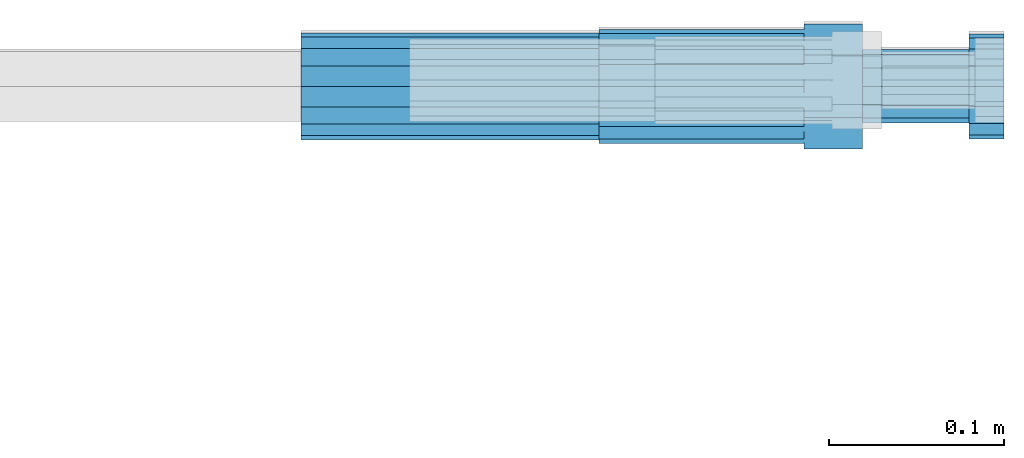
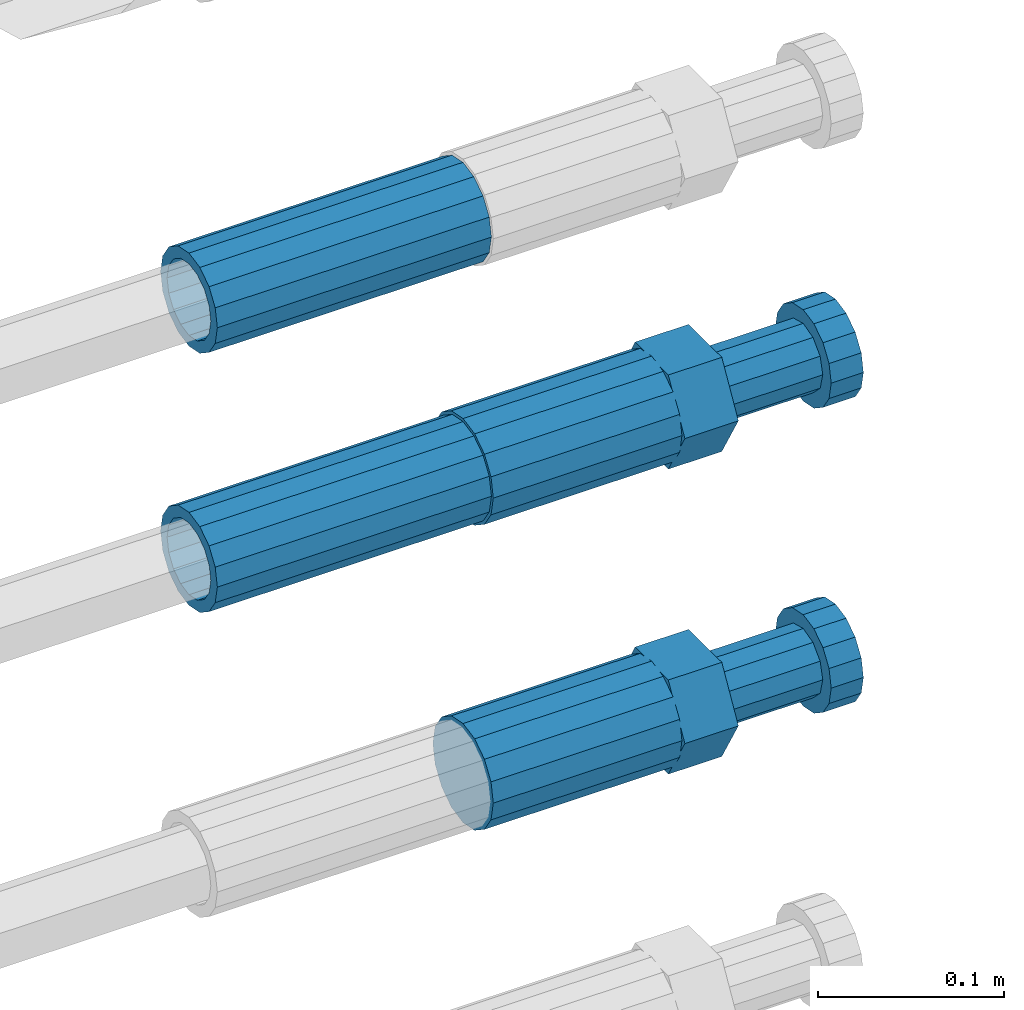
# One storey, part 116 of 119: 4 beams.
"""IFC2X3 building model written with IfcOpenShell, lengths in millimetres."""

from ifc_helpers import new_model, si_unit, frame, origin_with_axes, place, context, subcontext, project, spatial, faceted_brep, material, type_object, element, save


model = new_model("IFC2X3")

# Units and contexts
model_context = context("Model", 3, precision=1e-05, world=origin_with_axes())
body_context = subcontext(model_context, "Body", "Model", "MODEL_VIEW")
ifc_project = project(units=[si_unit("LENGTHUNIT", "METRE", prefix="MILLI"), si_unit("AREAUNIT", "SQUARE_METRE"), si_unit("VOLUMEUNIT", "CUBIC_METRE"), si_unit("MASSUNIT", "GRAM", prefix="KILO"), si_unit("TIMEUNIT", "SECOND"), si_unit("PLANEANGLEUNIT", "RADIAN"), si_unit("SOLIDANGLEUNIT", "STERADIAN"), si_unit("THERMODYNAMICTEMPERATUREUNIT", "DEGREE_CELSIUS"), si_unit("LUMINOUSINTENSITYUNIT", "LUMEN")], contexts=[model_context])

# Site, building, storey
site_placement = place(None, origin_with_axes())
site = spatial("IfcSite", under=ifc_project, at=site_placement, CompositionType="ELEMENT")
building_placement = place(site_placement, origin_with_axes())
building = spatial("IfcBuilding", under=site, at=building_placement, Name="Undefined", CompositionType="ELEMENT")
storey_placement = place(building_placement, origin_with_axes())
storey = spatial("IfcBuildingStorey", under=building, at=storey_placement, Name="Undefined", CompositionType="ELEMENT", Elevation=0.0)

# Beams
ifc_material = material(Name="STEEL/S275")
beam_type_1 = type_object("IfcBeamType", PredefinedType="NOTDEFINED")
beam_1_placement = place(storey_placement, frame((2039349.03023304, 6206399.98994599, 21634.9894122711), z_axis=(0.0, 0.0, 1.0), x_axis=(1.0, 0.0, 0.0)))
element("IfcBeam", 1, at=beam_1_placement, inside=storey, type_object=beam_type_1, material=ifc_material, Name="AG40N", context=body_context, shape_type="Brep", body=[
    faceted_brep([(1.62981450557709e-09, -23.4999999990687, 0.0), (7.45058059692383e-09, -21.7111690142192, 8.99306066057534), (170.000002125278, -21.711168999318, 8.99306066022245), (170.000002127141, -23.4999999844003, -3.66071617463604e-10), (4.65661287307739e-09, -16.6170093587134, 16.6170093578889), (170.000002122484, -16.6170093440451, 16.6170093575288), (1.86264514923096e-09, -8.99306066217832, 21.7111690140277), (170.000002118759, -8.99306064750999, 21.7111690136603), (2.3283064365387e-10, 9.31322574615479e-10, 23.5), (170.000002114102, 1.28056854009628e-08, 23.4999999996485), (-6.51925802230835e-09, 8.99306065868586, 21.7111690140241), (170.00000211224, 8.99306067335419, 21.7111690136639), (-7.45058059692383e-09, 16.6170093561523, 16.6170093578853), (170.000002109446, 16.6170093708206, 16.6170093575324), (-9.31322574615479e-09, 21.711169013055, 8.99306066057534), (170.000002108514, 21.7111690277234, 8.99306066022245), (-1.16415321826935e-09, 23.5000000009313, 0.0), (170.000002108514, 23.5000000144355, -3.66071617463604e-10), (-8.38190317153931e-09, 21.7111690151505, -8.99306066059444), (170.000002110377, 21.7111690300517, -8.9930606609546), (-5.58793544769287e-09, 16.6170093598776, -16.6170093579008), (170.000002113171, 16.6170093745459, -16.6170093582609), (-9.31322574615479e-10, 8.99306066334248, -21.7111690140396), (170.000002115965, 8.99306067801081, -21.7111690143961), (2.3283064365387e-10, 9.31322574615479e-10, -23.5), (170.00000211969, 1.7927959561348e-08, -23.5000000003843), (5.58793544769287e-09, -8.99306065752171, -21.7111690140396), (170.000002123415, -8.99306064285338, -21.7111690143961), (8.38190317153931e-09, -16.6170093549881, -16.6170093579008), (170.000002125278, -16.6170093403198, -16.6170093582646), (9.31322574615479e-09, -21.7111690121237, -8.99306066059444), (170.000002127141, -21.7111689972226, -8.9930606609546), (1.11758708953857e-08, -30.4999999990687, -9.54969436861575e-12), (1.30385160446167e-08, -28.1783257392235, -11.6718446871514), (170.000002129003, -28.1783257243223, -11.6718446875116), (170.000002129935, -30.4999999841675, -3.66071617463604e-10), (1.02445483207703e-08, -21.5667568228673, -21.5667568262129), (170.000002128072, -21.566756808199, -21.5667568265694), (7.45058059692383e-09, -11.6718446831219, -28.1783257416196), (170.000002125278, -11.6718446684536, -28.1783257419834), (3.72529029846191e-09, 3.95812094211578e-09, -30.5000000000277), (170.00000211969, 1.83936208486557e-08, -30.5000000003879), (-9.31322574615479e-10, 11.6718446905725, -28.1783257416232), (170.000002115965, 11.6718447052408, -28.1783257419797), (-6.51925802230835e-09, 21.5667568286881, -21.5667568262093), (170.000002110377, 21.5667568433564, -21.5667568265694), (-9.31322574615479e-09, 28.178325742716, -11.6718446871478), (170.000002108514, 28.1783257573843, -11.6718446875079), (-1.21071934700012e-08, 30.5, -5.91171556152403e-12), (170.000002106652, 30.5000000144355, -3.62433638656512e-10), (-1.21071934700012e-08, 28.1783257401548, 11.6718446871359), (170.00000210572, 28.1783257548232, 11.6718446867794), (-1.02445483207703e-08, 21.5667568240315, 21.5667568261974), (170.000002107583, 21.566756838467, 21.5667568258409), (-7.45058059692383e-09, 11.671844684286, 28.1783257416041), (170.000002110377, 11.6718446989544, 28.178325741244), (-2.79396772384644e-09, -2.56113708019257e-09, 30.5000000000159), (170.000002114102, 1.18743628263474e-08, 30.4999999996558), (1.86264514923096e-09, -11.6718446896411, 28.1783257416114), (170.000002118759, -11.67184467474, 28.178325741244), (7.45058059692383e-09, -21.5667568275239, 21.5667568261974), (170.000002123415, -21.5667568126228, 21.5667568258373), (1.02445483207703e-08, -28.1783257415518, 11.6718446871359), (170.000002127141, -28.1783257271163, 11.6718446867794)], [[[0, 1, 2, 3]], [[1, 4, 5, 2]], [[4, 6, 7, 5]], [[6, 8, 9, 7]], [[8, 10, 11, 9]], [[10, 12, 13, 11]], [[12, 14, 15, 13]], [[14, 16, 17, 15]], [[16, 18, 19, 17]], [[18, 20, 21, 19]], [[20, 22, 23, 21]], [[22, 24, 25, 23]], [[24, 26, 27, 25]], [[26, 28, 29, 27]], [[28, 30, 31, 29]], [[30, 0, 3, 31]], [[32, 33, 34, 35]], [[33, 36, 37, 34]], [[36, 38, 39, 37]], [[38, 40, 41, 39]], [[40, 42, 43, 41]], [[42, 44, 45, 43]], [[44, 46, 47, 45]], [[46, 48, 49, 47]], [[48, 50, 51, 49]], [[50, 52, 53, 51]], [[52, 54, 55, 53]], [[54, 56, 57, 55]], [[56, 58, 59, 57]], [[58, 60, 61, 59]], [[60, 62, 63, 61]], [[62, 32, 35, 63]], [[37, 39, 41, 43, 45, 47, 49, 51, 53, 55, 57, 59, 61, 63, 35, 34], [5, 7, 9, 11, 13, 15, 17, 19, 21, 23, 25, 27, 29, 31, 3, 2]], [[62, 60, 58, 56, 54, 52, 50, 48, 46, 44, 42, 40, 38, 36, 33, 32], [30, 28, 26, 24, 22, 20, 18, 16, 14, 12, 10, 8, 6, 4, 1, 0]]]),
])
beam_2_placement = place(storey_placement, frame((2039349.03023304, 6206399.98994599, 21804.9894122711), z_axis=(0.0, 0.0, 1.0), x_axis=(1.0, 0.0, 0.0)))
element("IfcBeam", 2, at=beam_2_placement, inside=storey, type_object=beam_type_1, material=ifc_material, Name="AG40N", context=body_context, shape_type="Brep", body=[
    faceted_brep([(1.62981450557709e-09, -23.4999999990687, 0.0), (7.45058059692383e-09, -21.7111690142192, 8.99306066057534), (170.000002125278, -21.711168999318, 8.99306066022245), (170.000002127141, -23.4999999844003, -3.66071617463604e-10), (4.65661287307739e-09, -16.6170093587134, 16.6170093578889), (170.000002122484, -16.6170093440451, 16.6170093575288), (1.86264514923096e-09, -8.99306066217832, 21.7111690140277), (170.000002118759, -8.99306064750999, 21.7111690136603), (2.3283064365387e-10, 9.31322574615479e-10, 23.5), (170.000002114102, 1.28056854009628e-08, 23.4999999996485), (-6.51925802230835e-09, 8.99306065868586, 21.7111690140241), (170.00000211224, 8.99306067335419, 21.7111690136639), (-7.45058059692383e-09, 16.6170093561523, 16.6170093578853), (170.000002109446, 16.6170093708206, 16.6170093575324), (-9.31322574615479e-09, 21.711169013055, 8.99306066057534), (170.000002108514, 21.7111690277234, 8.99306066022245), (-1.16415321826935e-09, 23.5000000009313, 0.0), (170.000002108514, 23.5000000144355, -3.66071617463604e-10), (-8.38190317153931e-09, 21.7111690151505, -8.99306066059444), (170.000002110377, 21.7111690300517, -8.9930606609546), (-5.58793544769287e-09, 16.6170093598776, -16.6170093579008), (170.000002113171, 16.6170093745459, -16.6170093582609), (-9.31322574615479e-10, 8.99306066334248, -21.7111690140396), (170.000002115965, 8.99306067801081, -21.7111690143961), (2.3283064365387e-10, 9.31322574615479e-10, -23.5), (170.00000211969, 1.7927959561348e-08, -23.5000000003843), (5.58793544769287e-09, -8.99306065752171, -21.7111690140396), (170.000002123415, -8.99306064285338, -21.7111690143961), (8.38190317153931e-09, -16.6170093549881, -16.6170093579008), (170.000002125278, -16.6170093403198, -16.6170093582646), (9.31322574615479e-09, -21.7111690121237, -8.99306066059444), (170.000002127141, -21.7111689972226, -8.9930606609546), (1.11758708953857e-08, -30.4999999990687, -9.54969436861575e-12), (1.30385160446167e-08, -28.1783257392235, -11.6718446871514), (170.000002129003, -28.1783257243223, -11.6718446875116), (170.000002129935, -30.4999999841675, -3.66071617463604e-10), (1.02445483207703e-08, -21.5667568228673, -21.5667568262129), (170.000002128072, -21.566756808199, -21.5667568265694), (7.45058059692383e-09, -11.6718446831219, -28.1783257416196), (170.000002125278, -11.6718446684536, -28.1783257419834), (3.72529029846191e-09, 3.95812094211578e-09, -30.5000000000277), (170.00000211969, 1.83936208486557e-08, -30.5000000003879), (-9.31322574615479e-10, 11.6718446905725, -28.1783257416232), (170.000002115965, 11.6718447052408, -28.1783257419797), (-6.51925802230835e-09, 21.5667568286881, -21.5667568262093), (170.000002110377, 21.5667568433564, -21.5667568265694), (-9.31322574615479e-09, 28.178325742716, -11.6718446871478), (170.000002108514, 28.1783257573843, -11.6718446875079), (-1.21071934700012e-08, 30.5, -5.91171556152403e-12), (170.000002106652, 30.5000000144355, -3.62433638656512e-10), (-1.21071934700012e-08, 28.1783257401548, 11.6718446871359), (170.00000210572, 28.1783257548232, 11.6718446867794), (-1.02445483207703e-08, 21.5667568240315, 21.5667568261974), (170.000002107583, 21.566756838467, 21.5667568258409), (-7.45058059692383e-09, 11.671844684286, 28.1783257416041), (170.000002110377, 11.6718446989544, 28.178325741244), (-2.79396772384644e-09, -2.56113708019257e-09, 30.5000000000159), (170.000002114102, 1.18743628263474e-08, 30.4999999996558), (1.86264514923096e-09, -11.6718446896411, 28.1783257416114), (170.000002118759, -11.67184467474, 28.178325741244), (7.45058059692383e-09, -21.5667568275239, 21.5667568261974), (170.000002123415, -21.5667568126228, 21.5667568258373), (1.02445483207703e-08, -28.1783257415518, 11.6718446871359), (170.000002127141, -28.1783257271163, 11.6718446867794)], [[[0, 1, 2, 3]], [[1, 4, 5, 2]], [[4, 6, 7, 5]], [[6, 8, 9, 7]], [[8, 10, 11, 9]], [[10, 12, 13, 11]], [[12, 14, 15, 13]], [[14, 16, 17, 15]], [[16, 18, 19, 17]], [[18, 20, 21, 19]], [[20, 22, 23, 21]], [[22, 24, 25, 23]], [[24, 26, 27, 25]], [[26, 28, 29, 27]], [[28, 30, 31, 29]], [[30, 0, 3, 31]], [[32, 33, 34, 35]], [[33, 36, 37, 34]], [[36, 38, 39, 37]], [[38, 40, 41, 39]], [[40, 42, 43, 41]], [[42, 44, 45, 43]], [[44, 46, 47, 45]], [[46, 48, 49, 47]], [[48, 50, 51, 49]], [[50, 52, 53, 51]], [[52, 54, 55, 53]], [[54, 56, 57, 55]], [[56, 58, 59, 57]], [[58, 60, 61, 59]], [[60, 62, 63, 61]], [[62, 32, 35, 63]], [[37, 39, 41, 43, 45, 47, 49, 51, 53, 55, 57, 59, 61, 63, 35, 34], [5, 7, 9, 11, 13, 15, 17, 19, 21, 23, 25, 27, 29, 31, 3, 2]], [[62, 60, 58, 56, 54, 52, 50, 48, 46, 44, 42, 40, 38, 36, 33, 32], [30, 28, 26, 24, 22, 20, 18, 16, 14, 12, 10, 8, 6, 4, 1, 0]]]),
])
beam_type_2 = type_object("IfcBeamType", Name="ROD65", PredefinedType="NOTDEFINED")
beam_3_placement = place(storey_placement, frame((2039519.03023304, 6206399.98994599, 21434.9894143674), z_axis=(0.0, 0.0, 1.0), x_axis=(1.0, 0.0, 0.0)))
element("IfcBeam", 3, at=beam_3_placement, inside=storey, type_object=beam_type_2, material=ifc_material, Name="AGB40", ObjectType="ROD65", context=body_context, shape_type="Brep", body=[
    faceted_brep([(116.999999999069, 17.8249999252148, 30.8738056446964), (116.999999998137, 22.0056957420893, 23.632628078838), (116.999999999069, 12.4372115600854, 30.0260848066173), (116.999999999069, 8.17543111252598, 30.8738056446964), (117.000000000931, -17.8250000746921, 30.8738056446964), (150.200000001118, -17.8250000723638, 30.8738056446964), (150.199999999255, 17.8249999275431, 30.8738056446964), (117.000000000931, -8.17543109622784, 30.8738056446964), (117.000000001863, -22.0056959956419, 23.6326278985034), (117.000000000931, -12.4372115437873, 30.0260848066173), (117.000000001863, -35.6500000746455, -2.18278728425503e-10), (150.200000002049, -35.6500000723172, -2.18278728425503e-10), (117.000000001863, -30.8443149488885, 8.32369080289209), (117.000000001863, -30.8443149488885, -8.32369080355784), (117.000000002794, -32.4999999918509, 0.0), (117.000000000931, -17.8250000746921, -30.873805645133), (150.200000001118, -17.8250000723638, -30.873805645133), (117.000000001863, -22.0056959961075, -23.6326278982269), (117.000000000931, -8.17543109389953, -30.873805645133), (117.000000000931, -12.4372115437873, -30.0260848066173), (116.999999999069, 17.8249999252148, -30.873805645133), (150.199999999255, 17.8249999275431, -30.873805645133), (116.999999999069, 8.17543111019768, -30.873805645133), (116.999999999069, 12.4372115600854, -30.0260848066173), (116.999999998137, 22.005695742555, -23.6326280785652), (116.999999998137, 35.6499999251682, -2.18278728425503e-10), (150.199999998324, 35.6499999277294, -2.18278728425503e-10), (116.999999998137, 30.8443150522653, -8.32369036550881), (116.999999997206, 32.5000000081491, 0.0), (116.999999998137, 30.8443150522653, 8.32369036483942), (1.86264514923096e-09, -22.9809703885112, 22.9809703885621), (1.86264514923096e-09, -30.0260848065373, 12.4372115518672), (117.000000001863, -30.0260847983882, 12.4372115518672), (117.000000001863, -22.9809703803621, 22.9809703885621), (-1.86264514923096e-09, 22.9809703885112, -22.9809703885621), (-1.86264514923096e-09, 30.0260848065373, -12.4372115518672), (116.999999998137, 30.0260848146863, -12.4372115518672), (116.999999998137, 22.9809703966603, -22.9809703885621), (1.86264514923096e-09, -30.0260848065373, -12.4372115518672), (1.86264514923096e-09, -22.9809703885112, -22.9809703885621), (117.000000001863, -22.9809703803621, -22.9809703885621), (117.000000001863, -30.0260847983882, -12.4372115518672), (9.31322574615479e-10, -12.4372115519363, 30.0260848066173), (0.0, 0.0, 32.5), (-9.31322574615479e-10, 12.4372115519363, 30.0260848066173), (-1.86264514923096e-09, 22.9809703885112, 22.9809703885621), (-1.86264514923096e-09, 30.0260848065373, 12.4372115518672), (-2.79396772384644e-09, 32.5, 0.0), (-9.31322574615479e-10, 12.4372115519363, -30.0260848066173), (0.0, 0.0, -32.5), (9.31322574615479e-10, -12.4372115519363, -30.0260848066173), (2.79396772384644e-09, -32.5, 0.0), (116.999999998137, 22.9809703966603, 22.9809703885621), (116.999999998137, 30.0260848146863, 12.4372115518672), (117.0, 8.14907252788544e-09, -32.5), (117.0, 8.14907252788544e-09, 32.5), (150.200000000186, -10.5000000959262, 18.1865334791873), (150.199999999255, -9.59262251853943e-08, 20.9999999997126), (150.199999998324, 10.4999999040738, 18.1865334791873), (150.199999997392, 18.1865333835594, 10.4999999997126), (150.199999997392, 20.9999999040738, -2.87400325760245e-10), (150.199999997392, 18.1865333835594, -10.5000000002874), (150.199999998324, 10.4999999040738, -18.1865334797621), (150.199999999255, -9.59262251853943e-08, -21.0000000002874), (150.200000000186, -10.5000000959262, -18.1865334797621), (150.200000000186, -18.1865335754119, -10.5000000002874), (150.200000001118, -21.0000000959262, -2.87400325760245e-10), (150.200000000186, -18.1865335754119, 10.4999999997126), (210.979999999516, 10.4999999082647, 18.1865334791873), (210.979999999516, -9.17352735996246e-08, 20.9999999997126), (210.979999997653, 18.1865333877504, 10.4999999997126), (210.979999997653, 20.9999999082647, -2.87400325760245e-10), (210.979999997653, 18.1865333877504, -10.5000000002874), (210.979999999516, 10.4999999082647, -18.1865334797621), (210.979999999516, -9.17352735996246e-08, -21.0000000002874), (210.979999999516, -10.5000000917353, -18.1865334797621), (210.980000000447, -18.1865335712209, -10.5000000002874), (210.980000001378, -21.0000000917353, -2.87400325760245e-10), (210.980000000447, -18.1865335712209, 10.4999999997126), (210.979999999516, -10.5000000917353, 18.1865334791873), (211.001368402503, -27.7269939335529, -11.4911163272045), (211.003082515672, -21.2238095656503, -21.2238154190527), (231.002518340945, -21.2131946226582, -21.2132004554769), (231.000804228708, -27.7163789905608, -11.4805013636287), (211.001368415542, -11.4911086384673, -27.7269970399575), (231.000804241747, -11.4804936954752, -27.7163820763781), (210.996487061493, -0.0106066407170147, -30.0106107396168), (230.995922887698, 8.30227509140968e-06, -29.999995776041), (210.98918159306, 11.4698940692469, -27.7269970332745), (230.988617419265, 11.4805090120062, -27.7163820696951), (210.980564201251, 21.2025913291145, -21.2238154067054), (230.980000027455, 21.2132062721066, -21.2132004431296), (210.971946807578, 27.7057702087332, -11.4911163110701), (230.971382633783, 27.7163851517253, -11.4805013474943), (210.964641331695, 29.9893806746695, -0.0106149565435771), (230.9640771579, 29.9999956176616, 7.03221303410828e-09), (210.959759964608, 27.7057637346443, 11.4698863966551), (230.959195790812, 27.7163786776364, 11.4805013602345), (210.958045851439, 21.2025793667417, 21.2025854885032), (230.957481677644, 21.2131943097338, 21.2132004520827), (210.959759951569, 11.4698784395587, 27.705767109408), (230.959195776843, 11.4804933823179, 27.7163820729838), (210.964641305618, -0.0106235581915826, 29.9893808090674), (230.964077131823, -8.61519947648048e-06, 29.9999957726432), (210.971946774051, -11.4911242681555, 27.7057671027251), (230.971382599324, -11.4805093251634, 27.7163820663009), (210.98056416586, -21.2238215280231, 21.2025854761559), (230.979999991134, -21.2132065852638, 21.2132004397354), (210.989181559533, -27.7270004076418, 11.4698863805206), (230.988617384806, -27.7163854646496, 11.4805013441), (210.996487035416, -30.0106108735781, -0.0106149740058754), (230.995922861621, -29.999995930586, -1.04300852399319e-08)], [[[0, 1, 2, 3]], [[4, 5, 6, 0, 3, 7]], [[8, 4, 7, 9]], [[10, 11, 5, 4, 8, 12]], [[13, 10, 12, 14]], [[15, 16, 11, 10, 13, 17]], [[18, 15, 17, 19]], [[20, 21, 16, 15, 18, 22]], [[20, 22, 23, 24]], [[25, 26, 21, 20, 24, 27]], [[25, 27, 28, 29]], [[30, 31, 32, 33]], [[34, 35, 36, 37]], [[38, 39, 40, 41]], [[31, 30, 42, 43, 44, 45, 46, 47, 35, 34, 48, 49, 50, 39, 38, 51]], [[46, 45, 52, 53]], [[28, 47, 46, 53, 29]], [[27, 36, 35, 47, 28]], [[24, 37, 36, 27]], [[23, 48, 34, 37, 24]], [[22, 54, 49, 48, 23]], [[18, 54, 22]], [[19, 50, 49, 54, 18]], [[17, 40, 39, 50, 19]], [[13, 41, 40, 17]], [[14, 51, 38, 41, 13]], [[12, 32, 31, 51, 14]], [[8, 33, 32, 12]], [[9, 42, 30, 33, 8]], [[7, 55, 43, 42, 9]], [[3, 55, 7]], [[2, 44, 43, 55, 3]], [[1, 52, 45, 44, 2]], [[29, 53, 52, 1]], [[0, 6, 26, 25, 29, 1]], [[5, 11, 16, 21, 26, 6], [56, 57, 58, 59, 60, 61, 62, 63, 64, 65, 66, 67]], [[68, 58, 57, 69]], [[70, 59, 58, 68]], [[71, 60, 59, 70]], [[72, 61, 60, 71]], [[73, 62, 61, 72]], [[74, 63, 62, 73]], [[75, 64, 63, 74]], [[76, 65, 64, 75]], [[77, 66, 65, 76]], [[78, 67, 66, 77]], [[79, 56, 67, 78]], [[69, 57, 56, 79]], [[80, 81, 82, 83]], [[81, 84, 85, 82]], [[84, 86, 87, 85]], [[86, 88, 89, 87]], [[88, 90, 91, 89]], [[90, 92, 93, 91]], [[92, 94, 95, 93]], [[94, 96, 97, 95]], [[96, 98, 99, 97]], [[98, 100, 101, 99]], [[100, 102, 103, 101]], [[102, 104, 105, 103]], [[104, 106, 107, 105]], [[106, 108, 109, 107]], [[108, 110, 111, 109]], [[82, 85, 87, 89, 91, 93, 95, 97, 99, 101, 103, 105, 107, 109, 111, 83]], [[110, 80, 83, 111]], [[108, 106, 104, 102, 100, 98, 96, 94, 92, 90, 88, 86, 84, 81, 80, 110], [78, 77, 76, 75, 74, 73, 72, 71, 70, 68, 69, 79]]]),
])
beam_4_placement = place(storey_placement, frame((2039519.03023304, 6206399.98994599, 21634.9894143674), z_axis=(0.0, 0.0, 1.0), x_axis=(1.0, 0.0, 0.0)))
element("IfcBeam", 4, at=beam_4_placement, inside=storey, type_object=beam_type_2, material=ifc_material, Name="AGB40", ObjectType="ROD65", context=body_context, shape_type="Brep", body=[
    faceted_brep([(116.999999999069, 17.8249999252148, 30.8738056446964), (116.999999998137, 22.0056957420893, 23.632628078838), (116.999999999069, 12.4372115600854, 30.0260848066173), (116.999999999069, 8.17543111252598, 30.8738056446964), (117.000000000931, -17.8250000746921, 30.8738056446964), (150.200000001118, -17.8250000723638, 30.8738056446964), (150.199999999255, 17.8249999275431, 30.8738056446964), (117.000000000931, -8.17543109622784, 30.8738056446964), (117.000000001863, -22.0056959956419, 23.6326278985034), (117.000000000931, -12.4372115437873, 30.0260848066173), (117.000000001863, -35.6500000746455, -2.18278728425503e-10), (150.200000002049, -35.6500000723172, -2.18278728425503e-10), (117.000000001863, -30.8443149488885, 8.32369080289209), (117.000000001863, -30.8443149488885, -8.32369080355784), (117.000000002794, -32.4999999918509, 0.0), (117.000000000931, -17.8250000746921, -30.873805645133), (150.200000001118, -17.8250000723638, -30.873805645133), (117.000000001863, -22.0056959961075, -23.6326278982269), (117.000000000931, -8.17543109389953, -30.873805645133), (117.000000000931, -12.4372115437873, -30.0260848066173), (116.999999999069, 17.8249999252148, -30.873805645133), (150.199999999255, 17.8249999275431, -30.873805645133), (116.999999999069, 8.17543111019768, -30.873805645133), (116.999999999069, 12.4372115600854, -30.0260848066173), (116.999999998137, 22.005695742555, -23.6326280785652), (116.999999998137, 35.6499999251682, -2.18278728425503e-10), (150.199999998324, 35.6499999277294, -2.18278728425503e-10), (116.999999998137, 30.8443150522653, -8.32369036550881), (116.999999997206, 32.5000000081491, 0.0), (116.999999998137, 30.8443150522653, 8.32369036483942), (1.86264514923096e-09, -22.9809703885112, 22.9809703885621), (1.86264514923096e-09, -30.0260848065373, 12.4372115518672), (117.000000001863, -30.0260847983882, 12.4372115518672), (117.000000001863, -22.9809703803621, 22.9809703885621), (-1.86264514923096e-09, 22.9809703885112, -22.9809703885621), (-1.86264514923096e-09, 30.0260848065373, -12.4372115518672), (116.999999998137, 30.0260848146863, -12.4372115518672), (116.999999998137, 22.9809703966603, -22.9809703885621), (1.86264514923096e-09, -30.0260848065373, -12.4372115518672), (1.86264514923096e-09, -22.9809703885112, -22.9809703885621), (117.000000001863, -22.9809703803621, -22.9809703885621), (117.000000001863, -30.0260847983882, -12.4372115518672), (9.31322574615479e-10, -12.4372115519363, 30.0260848066173), (0.0, 0.0, 32.5), (-9.31322574615479e-10, 12.4372115519363, 30.0260848066173), (-1.86264514923096e-09, 22.9809703885112, 22.9809703885621), (-1.86264514923096e-09, 30.0260848065373, 12.4372115518672), (-2.79396772384644e-09, 32.5, 0.0), (-9.31322574615479e-10, 12.4372115519363, -30.0260848066173), (0.0, 0.0, -32.5), (9.31322574615479e-10, -12.4372115519363, -30.0260848066173), (2.79396772384644e-09, -32.5, 0.0), (116.999999998137, 22.9809703966603, 22.9809703885621), (116.999999998137, 30.0260848146863, 12.4372115518672), (117.0, 8.14907252788544e-09, -32.5), (117.0, 8.14907252788544e-09, 32.5), (150.200000000186, -10.5000000959262, 18.1865334791873), (150.199999999255, -9.59262251853943e-08, 20.9999999997126), (150.199999998324, 10.4999999040738, 18.1865334791873), (150.199999997392, 18.1865333835594, 10.4999999997126), (150.199999997392, 20.9999999040738, -2.87400325760245e-10), (150.199999997392, 18.1865333835594, -10.5000000002874), (150.199999998324, 10.4999999040738, -18.1865334797621), (150.199999999255, -9.59262251853943e-08, -21.0000000002874), (150.200000000186, -10.5000000959262, -18.1865334797621), (150.200000000186, -18.1865335754119, -10.5000000002874), (150.200000001118, -21.0000000959262, -2.87400325760245e-10), (150.200000000186, -18.1865335754119, 10.4999999997126), (210.979999999516, 10.4999999082647, 18.1865334791873), (210.979999999516, -9.17352735996246e-08, 20.9999999997126), (210.979999997653, 18.1865333877504, 10.4999999997126), (210.979999997653, 20.9999999082647, -2.87400325760245e-10), (210.979999997653, 18.1865333877504, -10.5000000002874), (210.979999999516, 10.4999999082647, -18.1865334797621), (210.979999999516, -9.17352735996246e-08, -21.0000000002874), (210.979999999516, -10.5000000917353, -18.1865334797621), (210.980000000447, -18.1865335712209, -10.5000000002874), (210.980000001378, -21.0000000917353, -2.87400325760245e-10), (210.980000000447, -18.1865335712209, 10.4999999997126), (210.979999999516, -10.5000000917353, 18.1865334791873), (211.001368402503, -27.7269939335529, -11.4911163272045), (211.003082515672, -21.2238095656503, -21.2238154190527), (231.002518340945, -21.2131946226582, -21.2132004554769), (231.000804228708, -27.7163789905608, -11.4805013636287), (211.001368415542, -11.4911086384673, -27.7269970399575), (231.000804241747, -11.4804936954752, -27.7163820763781), (210.996487061493, -0.0106066407170147, -30.0106107396168), (230.995922887698, 8.30227509140968e-06, -29.999995776041), (210.98918159306, 11.4698940692469, -27.7269970332745), (230.988617419265, 11.4805090120062, -27.7163820696951), (210.980564201251, 21.2025913291145, -21.2238154067054), (230.980000027455, 21.2132062721066, -21.2132004431296), (210.971946807578, 27.7057702087332, -11.4911163110701), (230.971382633783, 27.7163851517253, -11.4805013474943), (210.964641331695, 29.9893806746695, -0.0106149565435771), (230.9640771579, 29.9999956176616, 7.03221303410828e-09), (210.959759964608, 27.7057637346443, 11.4698863966551), (230.959195790812, 27.7163786776364, 11.4805013602345), (210.958045851439, 21.2025793667417, 21.2025854885032), (230.957481677644, 21.2131943097338, 21.2132004520827), (210.959759951569, 11.4698784395587, 27.705767109408), (230.959195776843, 11.4804933823179, 27.7163820729838), (210.964641305618, -0.0106235581915826, 29.9893808090674), (230.964077131823, -8.61519947648048e-06, 29.9999957726432), (210.971946774051, -11.4911242681555, 27.7057671027251), (230.971382599324, -11.4805093251634, 27.7163820663009), (210.98056416586, -21.2238215280231, 21.2025854761559), (230.979999991134, -21.2132065852638, 21.2132004397354), (210.989181559533, -27.7270004076418, 11.4698863805206), (230.988617384806, -27.7163854646496, 11.4805013441), (210.996487035416, -30.0106108735781, -0.0106149740058754), (230.995922861621, -29.999995930586, -1.04300852399319e-08)], [[[0, 1, 2, 3]], [[4, 5, 6, 0, 3, 7]], [[8, 4, 7, 9]], [[10, 11, 5, 4, 8, 12]], [[13, 10, 12, 14]], [[15, 16, 11, 10, 13, 17]], [[18, 15, 17, 19]], [[20, 21, 16, 15, 18, 22]], [[20, 22, 23, 24]], [[25, 26, 21, 20, 24, 27]], [[25, 27, 28, 29]], [[30, 31, 32, 33]], [[34, 35, 36, 37]], [[38, 39, 40, 41]], [[31, 30, 42, 43, 44, 45, 46, 47, 35, 34, 48, 49, 50, 39, 38, 51]], [[46, 45, 52, 53]], [[28, 47, 46, 53, 29]], [[27, 36, 35, 47, 28]], [[24, 37, 36, 27]], [[23, 48, 34, 37, 24]], [[22, 54, 49, 48, 23]], [[18, 54, 22]], [[19, 50, 49, 54, 18]], [[17, 40, 39, 50, 19]], [[13, 41, 40, 17]], [[14, 51, 38, 41, 13]], [[12, 32, 31, 51, 14]], [[8, 33, 32, 12]], [[9, 42, 30, 33, 8]], [[7, 55, 43, 42, 9]], [[3, 55, 7]], [[2, 44, 43, 55, 3]], [[1, 52, 45, 44, 2]], [[29, 53, 52, 1]], [[0, 6, 26, 25, 29, 1]], [[5, 11, 16, 21, 26, 6], [56, 57, 58, 59, 60, 61, 62, 63, 64, 65, 66, 67]], [[68, 58, 57, 69]], [[70, 59, 58, 68]], [[71, 60, 59, 70]], [[72, 61, 60, 71]], [[73, 62, 61, 72]], [[74, 63, 62, 73]], [[75, 64, 63, 74]], [[76, 65, 64, 75]], [[77, 66, 65, 76]], [[78, 67, 66, 77]], [[79, 56, 67, 78]], [[69, 57, 56, 79]], [[80, 81, 82, 83]], [[81, 84, 85, 82]], [[84, 86, 87, 85]], [[86, 88, 89, 87]], [[88, 90, 91, 89]], [[90, 92, 93, 91]], [[92, 94, 95, 93]], [[94, 96, 97, 95]], [[96, 98, 99, 97]], [[98, 100, 101, 99]], [[100, 102, 103, 101]], [[102, 104, 105, 103]], [[104, 106, 107, 105]], [[106, 108, 109, 107]], [[108, 110, 111, 109]], [[82, 85, 87, 89, 91, 93, 95, 97, 99, 101, 103, 105, 107, 109, 111, 83]], [[110, 80, 83, 111]], [[108, 106, 104, 102, 100, 98, 96, 94, 92, 90, 88, 86, 84, 81, 80, 110], [78, 77, 76, 75, 74, 73, 72, 71, 70, 68, 69, 79]]]),
])

save(model, "model.ifc")
